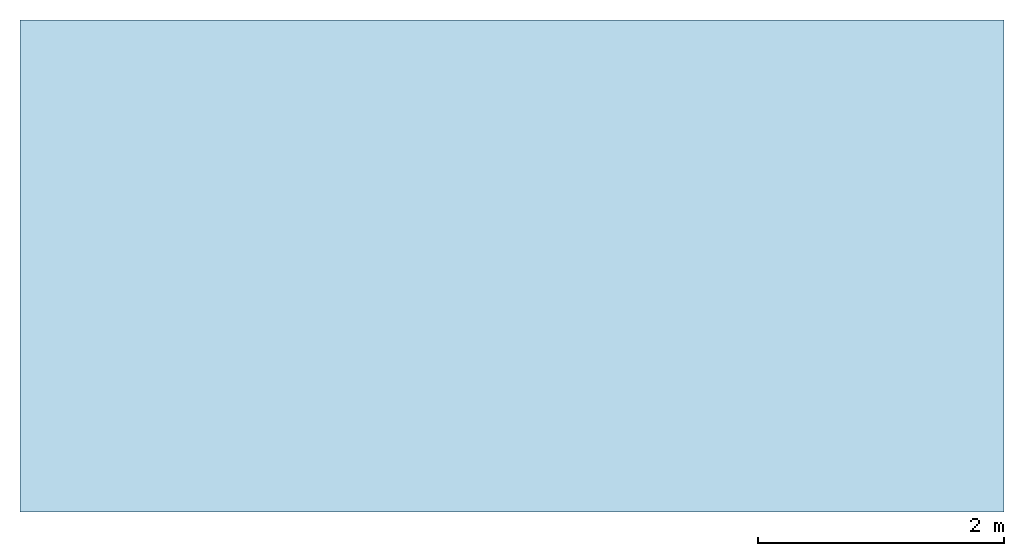
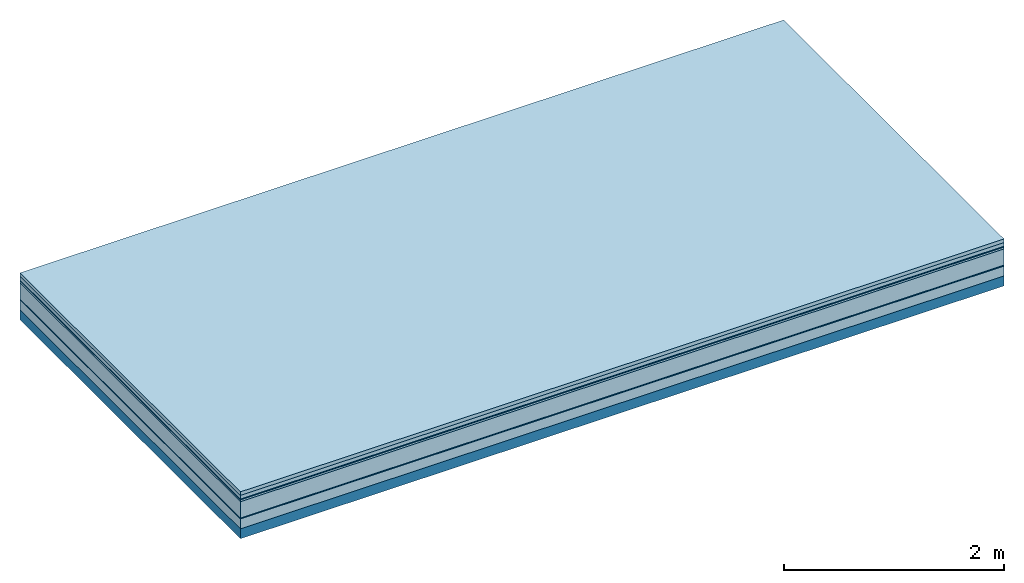
# One storey: 7 plates, 1 member, 1 element without a shape of its own.
"""IFC4 building model written with IfcOpenShell, lengths in metres."""

from ifc_helpers import new_model, si_unit, derived_unit, direction, frame, frame_2d, origin, origin_with_axes, place, context, project, spatial, rectangle, extrude, material, layer, layer_set, type_object, element, aggregate, save


model = new_model("IFC4")

# Units and contexts
plan_context = context("Plan", 3, precision=1e-05, world=origin(), true_north=direction((0.0, 1.0)))
model_context = context("Model", 3, precision=1e-05, world=origin(), true_north=direction((0.0, 1.0)))
ifc_project = project(units=[si_unit("LENGTHUNIT", "METRE"), derived_unit("SOUNDPRESSUREUNIT", [(si_unit("PRESSUREUNIT", "PASCAL", prefix="MICRO"), 0)]), si_unit("ENERGYUNIT", "JOULE", prefix="MEGA"), si_unit("MASSUNIT", "GRAM", prefix="KILO"), derived_unit("THERMALTRANSMITTANCEUNIT", [(si_unit("POWERUNIT", "WATT"), 1), (si_unit("AREAUNIT", "SQUARE_METRE"), -1), (si_unit("THERMODYNAMICTEMPERATUREUNIT", "KELVIN"), -1)]), derived_unit("AREADENSITYUNIT", [(si_unit("MASSUNIT", "GRAM", prefix="KILO"), 1), (si_unit("AREAUNIT", "SQUARE_METRE"), -1)]), derived_unit("USERDEFINED", [(si_unit("ENERGYUNIT", "JOULE", prefix="MEGA"), 1), (si_unit("AREAUNIT", "SQUARE_METRE"), -1)])], contexts=[plan_context, model_context])

# Site, building, storey
site = spatial("IfcSite", under=ifc_project)
building_placement = place(None, origin())
building = spatial("IfcBuilding", under=site, at=building_placement)
storey_placement = place(building_placement, origin())
storey = spatial("IfcBuildingStorey", under=building, at=storey_placement)

# Slab, member, plates
ifc_material_1 = material(Name="Garden plates", Category="02.007")
ifc_layer_1 = layer(ifc_material_1, 0.04, Name="Use and protection layer 3")
ifc_material_2 = material(Name="Gravel 8-16mm", Category="03.011")
ifc_layer_2 = layer(ifc_material_2, 0.04, Name="Use and protection layer 2")
ifc_material_3 = material(Name="Protective layer", Category="09.007")
ifc_layer_3 = layer(ifc_material_3, 0.01, Name="Use and protection layer 1")
ifc_material_4 = material(Name="Bituminous", Category="09.003")
ifc_layer_4 = layer(ifc_material_4, 0.02, Name="Seal")
ifc_material_5 = material(Name="Mineral wool", Category="10.008")
ifc_layer_5 = layer(ifc_material_5, 0.18, Name="Exterior insulation layer 1")
ifc_material_6 = material(Name="Vapor-permeable barrier", Category="09.006")
ifc_layer_6 = layer(ifc_material_6, 0.01, Name="layer / temporary roof")
ifc_material_7 = material(Category="01.002")
ifc_layer_7 = layer(ifc_material_7, 0.11, Name="above 1st layer")
ifc_material_8 = material(Name="Rigid, of the art")
ifc_layer_8 = layer(ifc_material_8, 0.0, Name="Bond")
ifc_layer_9 = layer(None, 0.11, Name="Support")
ifc_layer_set = layer_set([ifc_layer_1, ifc_layer_2, ifc_layer_3, ifc_layer_4, ifc_layer_5, ifc_layer_6, ifc_layer_7, ifc_layer_8, ifc_layer_9])
slab_type = type_object("IfcSlabType", Name="F0083", PredefinedType="NOTDEFINED", material=ifc_layer_set)
slab_placement = place(None, frame((0.0, 0.0, 0.0), z_axis=(0.0, 0.0, -1.0), x_axis=(1.0, 0.0, 0.0)))
slab = element("IfcSlab", 1, at=slab_placement, inside=storey, type_object=slab_type, material=ifc_layer_set, Name="Slab #1")
ifc_material_9 = material(Name="Solid timber panel")
member_placement = place(slab_placement, origin())
member = element("IfcMember", 2, at=member_placement, material=ifc_material_9, Name="Support", context=plan_context, shape_type="SweptSolid", body=[
    extrude(rectangle(XDim=1.0, YDim=0.11, at=frame_2d((0.5, 0.055), x_axis=(1.0, 0.0))), frame((0.0, 4.0, 0.41), z_axis=(0.0, -1.0, 0.0), x_axis=(1.0, 0.0, 0.0)), (0.0, 0.0, 1.0), 4.0),
    extrude(rectangle(XDim=1.0, YDim=0.11, at=frame_2d((0.5, 0.055), x_axis=(1.0, 0.0))), frame((1.0, 4.0, 0.41), z_axis=(0.0, -1.0, 0.0), x_axis=(1.0, 0.0, 0.0)), (0.0, 0.0, 1.0), 4.0),
    extrude(rectangle(XDim=1.0, YDim=0.11, at=frame_2d((0.5, 0.055), x_axis=(1.0, 0.0))), frame((2.0, 4.0, 0.41), z_axis=(0.0, -1.0, 0.0), x_axis=(1.0, 0.0, 0.0)), (0.0, 0.0, 1.0), 4.0),
    extrude(rectangle(XDim=1.0, YDim=0.11, at=frame_2d((0.5, 0.055), x_axis=(1.0, 0.0))), frame((3.0, 4.0, 0.41), z_axis=(0.0, -1.0, 0.0), x_axis=(1.0, 0.0, 0.0)), (0.0, 0.0, 1.0), 4.0),
    extrude(rectangle(XDim=1.0, YDim=0.11, at=frame_2d((0.5, 0.055), x_axis=(1.0, 0.0))), frame((4.0, 4.0, 0.41), z_axis=(0.0, -1.0, 0.0), x_axis=(1.0, 0.0, 0.0)), (0.0, 0.0, 1.0), 4.0),
    extrude(rectangle(XDim=1.0, YDim=0.11, at=frame_2d((0.5, 0.055), x_axis=(1.0, 0.0))), frame((5.0, 4.0, 0.41), z_axis=(0.0, -1.0, 0.0), x_axis=(1.0, 0.0, 0.0)), (0.0, 0.0, 1.0), 4.0),
    extrude(rectangle(XDim=1.0, YDim=0.11, at=frame_2d((0.5, 0.055), x_axis=(1.0, 0.0))), frame((6.0, 4.0, 0.41), z_axis=(0.0, -1.0, 0.0), x_axis=(1.0, 0.0, 0.0)), (0.0, 0.0, 1.0), 4.0),
    extrude(rectangle(XDim=1.0, YDim=0.11, at=frame_2d((0.5, 0.055), x_axis=(1.0, 0.0))), frame((7.0, 4.0, 0.41), z_axis=(0.0, -1.0, 0.0), x_axis=(1.0, 0.0, 0.0)), (0.0, 0.0, 1.0), 4.0),
])
plate_1_placement = place(slab_placement, origin())
plate_1 = element("IfcPlate", 3, at=plate_1_placement, material=ifc_material_1, Name="Use and protection layer 3", context=plan_context, shape_type="SweptSolid", body=[
    extrude(rectangle(XDim=8.0, YDim=4.0, at=frame_2d((4.0, 2.0), x_axis=(1.0, 0.0))), origin_with_axes(), (0.0, 0.0, 1.0), 0.04),
])
plate_2_placement = place(slab_placement, origin())
plate_2 = element("IfcPlate", 4, at=plate_2_placement, material=ifc_material_2, Name="Use and protection layer 2", context=plan_context, shape_type="SweptSolid", body=[
    extrude(rectangle(XDim=8.0, YDim=4.0, at=frame_2d((4.0, 2.0), x_axis=(1.0, 0.0))), frame((0.0, 0.0, 0.04), z_axis=(0.0, 0.0, 1.0), x_axis=(1.0, 0.0, 0.0)), (0.0, 0.0, 1.0), 0.04),
])
plate_3_placement = place(slab_placement, origin())
plate_3 = element("IfcPlate", 5, at=plate_3_placement, material=ifc_material_3, Name="Use and protection layer 1", context=plan_context, shape_type="SweptSolid", body=[
    extrude(rectangle(XDim=8.0, YDim=4.0, at=frame_2d((4.0, 2.0), x_axis=(1.0, 0.0))), frame((0.0, 0.0, 0.08), z_axis=(0.0, 0.0, 1.0), x_axis=(1.0, 0.0, 0.0)), (0.0, 0.0, 1.0), 0.01),
])
plate_4_placement = place(slab_placement, origin())
plate_4 = element("IfcPlate", 6, at=plate_4_placement, material=ifc_material_4, Name="Seal", context=plan_context, shape_type="SweptSolid", body=[
    extrude(rectangle(XDim=8.0, YDim=4.0, at=frame_2d((4.0, 2.0), x_axis=(1.0, 0.0))), frame((0.0, 0.0, 0.09), z_axis=(0.0, 0.0, 1.0), x_axis=(1.0, 0.0, 0.0)), (0.0, 0.0, 1.0), 0.02),
])
plate_5_placement = place(slab_placement, origin())
plate_5 = element("IfcPlate", 7, at=plate_5_placement, material=ifc_material_5, Name="Exterior insulation layer 1", context=plan_context, shape_type="SweptSolid", body=[
    extrude(rectangle(XDim=8.0, YDim=4.0, at=frame_2d((4.0, 2.0), x_axis=(1.0, 0.0))), frame((0.0, 0.0, 0.11), z_axis=(0.0, 0.0, 1.0), x_axis=(1.0, 0.0, 0.0)), (0.0, 0.0, 1.0), 0.18),
])
plate_6_placement = place(slab_placement, origin())
plate_6 = element("IfcPlate", 8, at=plate_6_placement, material=ifc_material_6, Name="layer / temporary roof", context=plan_context, shape_type="SweptSolid", body=[
    extrude(rectangle(XDim=8.0, YDim=4.0, at=frame_2d((4.0, 2.0), x_axis=(1.0, 0.0))), frame((0.0, 0.0, 0.29), z_axis=(0.0, 0.0, 1.0), x_axis=(1.0, 0.0, 0.0)), (0.0, 0.0, 1.0), 0.01),
])
plate_7_placement = place(slab_placement, origin())
plate_7 = element("IfcPlate", 9, at=plate_7_placement, material=ifc_material_7, Name="above 1st layer", context=plan_context, shape_type="SweptSolid", body=[
    extrude(rectangle(XDim=8.0, YDim=4.0, at=frame_2d((4.0, 2.0), x_axis=(1.0, 0.0))), frame((0.0, 0.0, 0.3), z_axis=(0.0, 0.0, 1.0), x_axis=(1.0, 0.0, 0.0)), (0.0, 0.0, 1.0), 0.11),
])
aggregate(slab, [plate_1, plate_2, plate_3, plate_4, plate_5, plate_6, plate_7, member])

save(model, "model.ifc")
